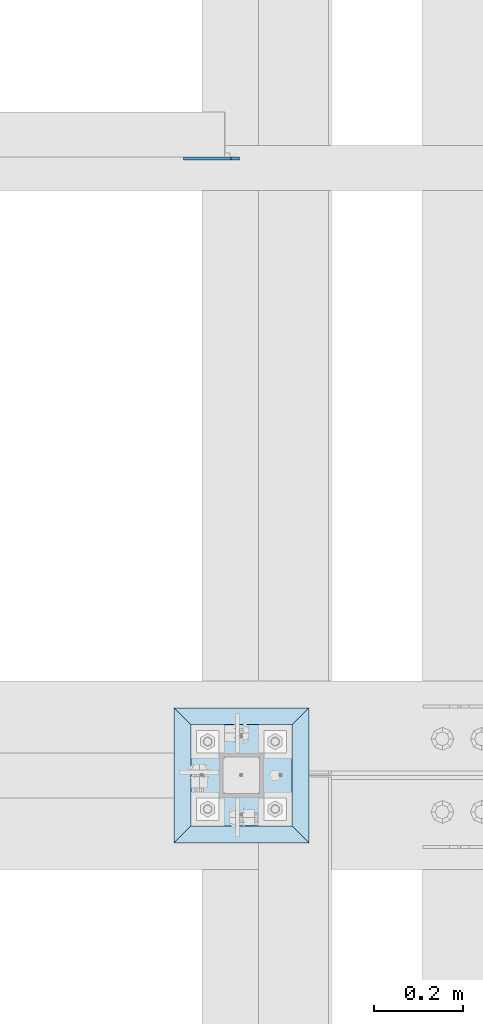
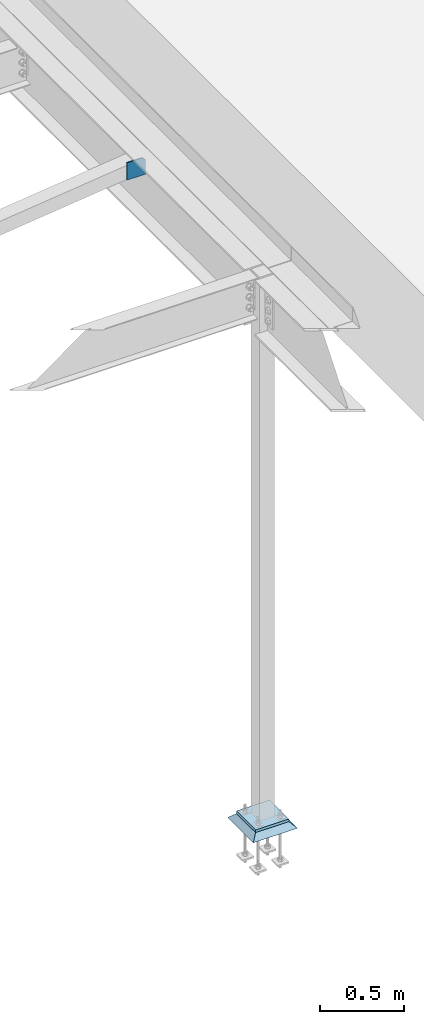
# One storey, part 3238 of 3843: 3 plates, 3 elements without a shape of their own.
"""IFC2X3 building model written with IfcOpenShell, lengths in millimetres."""

from ifc_helpers import new_model, si_unit, frame, origin_with_axes, place, context, subcontext, project, spatial, faceted_brep, material, type_object, element, aggregate, save


model = new_model("IFC2X3")

# Units and contexts
model_context = context("Model", 3, precision=1e-05, world=origin_with_axes())
body_context = subcontext(model_context, "Body", "Model", "MODEL_VIEW")
ifc_project = project(units=[si_unit("LENGTHUNIT", "METRE", prefix="MILLI"), si_unit("AREAUNIT", "SQUARE_METRE"), si_unit("VOLUMEUNIT", "CUBIC_METRE"), si_unit("MASSUNIT", "GRAM", prefix="KILO"), si_unit("TIMEUNIT", "SECOND"), si_unit("PLANEANGLEUNIT", "RADIAN"), si_unit("SOLIDANGLEUNIT", "STERADIAN"), si_unit("THERMODYNAMICTEMPERATUREUNIT", "DEGREE_CELSIUS"), si_unit("LUMINOUSINTENSITYUNIT", "LUMEN")], contexts=[model_context])

# Site, building, storey
site_placement = place(None, origin_with_axes())
site = spatial("IfcSite", under=ifc_project, at=site_placement, CompositionType="ELEMENT")
building_placement = place(site_placement, origin_with_axes())
building = spatial("IfcBuilding", under=site, at=building_placement, Name="Undefined", CompositionType="ELEMENT")
storey_placement = place(building_placement, origin_with_axes())
storey = spatial("IfcBuildingStorey", under=building, at=storey_placement, Name="Undefined", CompositionType="ELEMENT", Elevation=0.0)

# Assembly, plate
assembly_1_placement = place(storey_placement, origin_with_axes())
assembly_1 = element("IfcElementAssembly", 1, at=assembly_1_placement, inside=storey, Name="BEAM", AssemblyPlace="NOTDEFINED", PredefinedType="RIGID_FRAME")
ifc_material_1 = material(Name="STEEL/A572-50")
plate_type_1 = type_object("IfcPlateType", PredefinedType="NOTDEFINED")
plate_1_placement = place(assembly_1_placement, frame((38816.75625, 43594.833594, 33896.3), z_axis=(0.0, 0.0, 1.0), x_axis=(-1.0, 0.0, 0.0)))
plate_1 = element("IfcPlate", 2, at=plate_1_placement, type_object=plate_type_1, material=ifc_material_1, Name="PLATE", context=body_context, shape_type="Brep", body=[
    faceted_brep([(0.0, -3.17499999999927, 0.0), (0.0, -3.17500000000291, 107.950000000004), (0.0, 3.17500000000291, 107.950000000004), (0.0, 3.17499999999927, 0.0), (19.0500000000029, -3.17500000000291, 127.0), (19.0500000000029, 3.17500000000291, 127.0), (127.0, -3.17500000000291, 127.0), (127.0, 3.17500000000291, 127.0), (127.0, -3.17500000000291, 0.0), (127.0, 3.17500000000291, 0.0)], [[[0, 1, 2, 3]], [[1, 4, 5, 2]], [[4, 6, 7, 5]], [[6, 8, 9, 7]], [[8, 0, 3, 9]], [[5, 7, 9, 3, 2]], [[8, 6, 4, 1, 0]]]),
])
aggregate(assembly_1, [plate_1])

assembly_2_placement = place(storey_placement, origin_with_axes())
assembly_2 = element("IfcElementAssembly", 3, at=assembly_2_placement, inside=storey, Name="COLUMN", AssemblyPlace="NOTDEFINED", PredefinedType="RIGID_FRAME")
plate_type_2 = type_object("IfcPlateType", PredefinedType="NOTDEFINED")
plate_2_placement = place(assembly_2_placement, frame((38706.425, 42087.8, 30070.425), z_axis=(0.0, 1.0, 0.0), x_axis=(1.0, 0.0, 0.0)))
plate_2 = element("IfcPlate", 4, at=plate_2_placement, type_object=plate_type_2, material=ifc_material_1, Name="PLATE", context=body_context, shape_type="Brep", body=[
    faceted_brep([(0.0, -9.52500000000146, 0.0), (0.0, -9.52500000000146, 228.600006103516), (0.0, 9.52500000000146, 228.600006103516), (0.0, 9.52500000000146, 0.0), (228.600006103516, -9.52500000000146, 228.600006103516), (228.600006103516, 9.52500000000146, 228.600006103516), (228.599999999999, -9.52500000000146, 0.0), (228.599999999999, 9.52500000000146, 0.0)], [[[0, 1, 2, 3]], [[1, 4, 5, 2]], [[4, 6, 7, 5]], [[6, 0, 3, 7]], [[5, 7, 3, 2]], [[6, 4, 1, 0]]]),
])
aggregate(assembly_2, [plate_2])

assembly_3_placement = place(storey_placement, origin_with_axes())
assembly_3 = element("IfcElementAssembly", 5, at=assembly_3_placement, inside=storey, Name="GROUT", AssemblyPlace="NOTDEFINED", PredefinedType="REINFORCEMENT_UNIT")
ifc_material_2 = material(Name="CONCRETE/Concrete_Undefined")
plate_type_3 = type_object("IfcPlateType", PredefinedType="NOTDEFINED")
plate_3_placement = place(assembly_3_placement, frame((38668.325, 42049.7, 30041.85), z_axis=(0.0, 1.0, 0.0), x_axis=(1.0, 0.0, 0.0)))
plate_3 = element("IfcPlate", 6, at=plate_3_placement, type_object=plate_type_3, material=ifc_material_2, Name="GROUT", context=body_context, shape_type="Brep", body=[
    faceted_brep([(38.0999999997875, -19.0499999997883, 266.699999999328), (0.0, 19.0499999999993, 304.799987792969), (0.0, 19.0500000000029, 0.0), (38.1000000006916, -19.0499999999811, 38.1000000006607), (266.700000000201, -19.0499999998174, 38.1000000006752), (304.799987792969, 19.0499999999993, 0.0), (304.799987792969, 19.0499999999993, 304.799987792969), (266.700000000201, -19.0499999999738, 266.699999999328)], [[[0, 1, 2, 3]], [[4, 5, 6, 7]], [[4, 7, 0, 3]], [[5, 4, 3, 2]], [[6, 5, 2, 1]], [[7, 6, 1, 0]]]),
])
aggregate(assembly_3, [plate_3])

save(model, "model.ifc")
